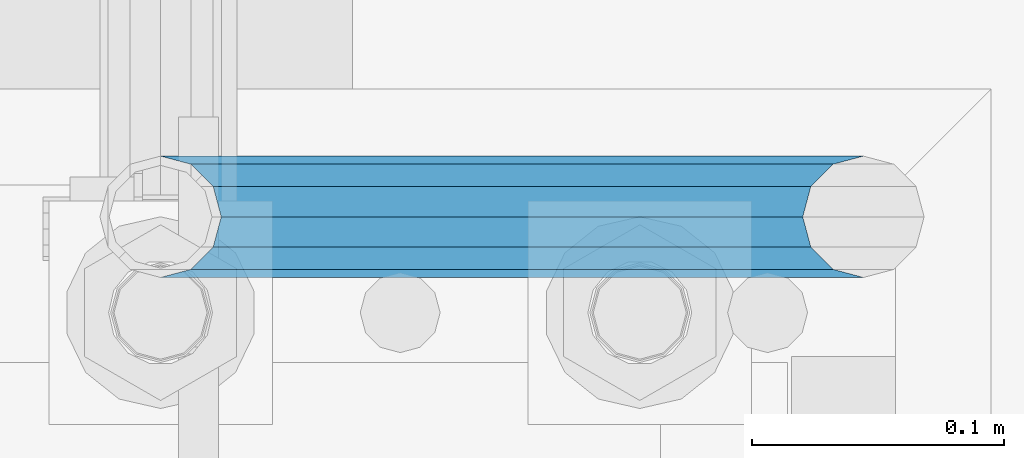
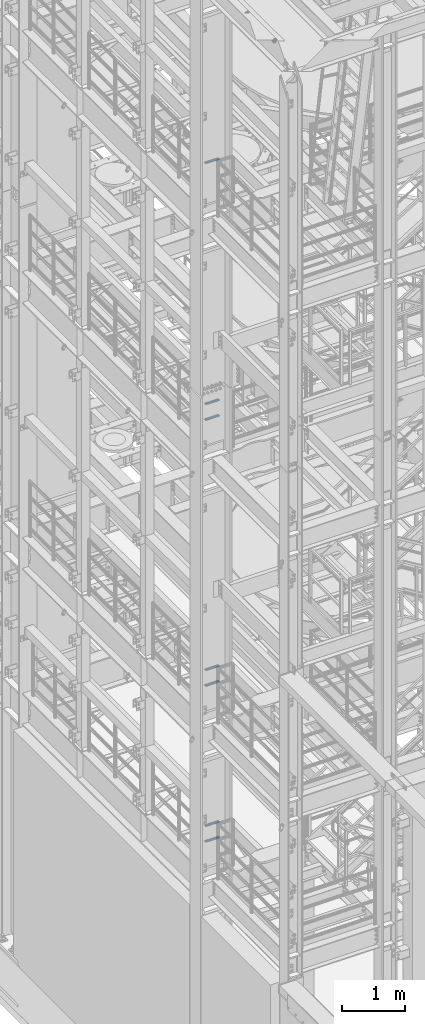
# One storey, part 1158 of 1876: 7 beams, 4 elements without a shape of their own.
"""IFC2X3 building model written with IfcOpenShell, lengths in millimetres."""

import ifcopenshell
import ifcopenshell.guid

model = None  # the IFC model being written
_history = None  # IfcOwnerHistory: only IFC2X3 demands one
_inside = {}  # id of a spatial element -> (the spatial element, [elements in it])
_under = {}  # id of a project, library or spatial element -> (it, [spatial elements below it])
_declared = {}  # id of a project -> (the project, [libraries it declares])
_typed = {}  # id of a type object -> (the type object, [elements of that type])
_made_of = {}  # id of a material, layer set ... -> (it, [elements and type objects made of it])


def new_model(schema):
    """Start an empty IFC model of exactly this schema.

    Asked for "IFC4X3", IfcOpenShell would pick the latest addendum, in which some entities
    have other attributes; the version numbers below select the first issue.
    IFC2X3 requires an IfcOwnerHistory on every rooted entity: one is made here for all.
    """
    global model, _history
    if schema == "IFC4X3":
        model = ifcopenshell.file(schema_version=(4, 3, 0, 0))
    else:
        model = ifcopenshell.file(schema=schema)
    _inside.clear()
    _under.clear()
    _declared.clear()
    _typed.clear()
    _made_of.clear()
    _history = None
    if model.schema == "IFC2X3":
        org = make("IfcOrganization", Name="unknown")
        user = make(
            "IfcPersonAndOrganization",
            ThePerson=make("IfcPerson", FamilyName="unknown"),
            TheOrganization=org,
        )
        app = make(
            "IfcApplication",
            ApplicationDeveloper=org,
            Version="unknown",
            ApplicationFullName="unknown",
            ApplicationIdentifier="unknown",
        )
        _history = make(
            "IfcOwnerHistory",
            OwningUser=user,
            OwningApplication=app,
            ChangeAction="ADDED",
            CreationDate=0,
        )
    return model


def make(cls, **values):
    """One entity of the class cls with the attributes given. An attribute that is None is left unset."""
    return model.create_entity(
        cls, **{name: value for name, value in values.items() if value is not None}
    )


def rooted(cls, **values):
    """An entity with a GlobalId (a new one), such as an element, a storey or a relation."""
    return make(cls, GlobalId=ifcopenshell.guid.new(), OwnerHistory=_history, **values)


def si_unit(unit_type, name, prefix=None):
    """IfcSIUnit, for example si_unit("LENGTHUNIT", "METRE", prefix="MILLI")."""
    return make("IfcSIUnit", UnitType=unit_type, Prefix=prefix, Name=name)


def assignment(units):
    """IfcUnitAssignment: the units of a project."""
    return None if units is None else make("IfcUnitAssignment", Units=units)


def point(xyz):
    """IfcCartesianPoint."""
    return None if xyz is None else make("IfcCartesianPoint", Coordinates=xyz)


def direction(xyz):
    """IfcDirection."""
    return None if xyz is None else make("IfcDirection", DirectionRatios=xyz)


def frame(location, z_axis=None, x_axis=None):
    """IfcAxis2Placement3D, a coordinate frame: its origin and axes. An axis left out is left unset."""
    return make(
        "IfcAxis2Placement3D",
        Location=point(location),
        Axis=direction(z_axis),
        RefDirection=direction(x_axis),
    )


def origin_with_axes():
    """The frame at (0, 0, 0) with the z axis (0, 0, 1) and the x axis (1, 0, 0) written out."""
    return frame((0.0, 0.0, 0.0), z_axis=(0.0, 0.0, 1.0), x_axis=(1.0, 0.0, 0.0))


def place(relative_to, where):
    """IfcLocalPlacement: puts the frame where relative to a parent placement (None: the world)."""
    return make(
        "IfcLocalPlacement", PlacementRelTo=relative_to, RelativePlacement=where
    )


def context(
    kind, dimensions, precision=None, world=None, true_north=None, identifier=None
):
    """IfcGeometricRepresentationContext, for example the 3D "Model" context."""
    return make(
        "IfcGeometricRepresentationContext",
        ContextIdentifier=identifier,
        ContextType=kind,
        CoordinateSpaceDimension=dimensions,
        Precision=precision,
        WorldCoordinateSystem=world,
        TrueNorth=true_north,
    )


def subcontext(parent, identifier, kind, view, scale=None):
    """IfcGeometricRepresentationSubContext, for example "Body" below "Model"."""
    return make(
        "IfcGeometricRepresentationSubContext",
        ContextIdentifier=identifier,
        ContextType=kind,
        ParentContext=parent,
        TargetScale=scale,
        TargetView=view,
    )


def project(units=None, contexts=None):
    """IfcProject with its units and contexts."""
    return rooted(
        "IfcProject",
        Name="project",
        RepresentationContexts=contexts,
        UnitsInContext=assignment(units),
    )


def spatial(cls, under=None, at=None, **own):
    """A site, building, storey or space (cls), placed at a placement, below another one or the project."""
    s = rooted(cls, ObjectPlacement=at, **own)
    if under is not None:
        _under.setdefault(under.id(), (under, []))[1].append(s)
    return s


def faces_of(points, faces, orient=None, outer=None):
    """IfcFace entities. A face is a list of loops; a loop is a list of indices into points, from 0.

    orient and outer hold one flag for each loop. By default every Orientation is true, the
    first loop of a face is its IfcFaceOuterBound and the others are IfcFaceBound.
    """
    made = []
    for i, loops in enumerate(faces):
        bounds = []
        for j, loop in enumerate(loops):
            is_outer = j == 0 if outer is None else outer[i][j]
            bounds.append(
                make(
                    "IfcFaceOuterBound" if is_outer else "IfcFaceBound",
                    Bound=make("IfcPolyLoop", Polygon=[points[k] for k in loop]),
                    Orientation=True if orient is None else orient[i][j],
                )
            )
        made.append(make("IfcFace", Bounds=bounds))
    return made


def faceted_brep(points, faces, orient=None, outer=None, voids=None):
    """IfcFacetedBrep: a solid bounded by flat faces; with voids (closed shells), ...WithVoids."""
    shared = [point(p) for p in points]
    hull = make("IfcClosedShell", CfsFaces=faces_of(shared, faces, orient, outer))
    if voids is None:
        return make("IfcFacetedBrep", Outer=hull)
    return make(
        "IfcFacetedBrepWithVoids",
        Outer=hull,
        Voids=[
            make(cls, CfsFaces=faces_of(shared, fs, o, b)) for cls, fs, o, b in voids
        ],
    )


def shape(context_of_items, identifier, shape_type, items):
    """IfcShapeRepresentation: the items that make up one representation, for example the "Body"."""
    return make(
        "IfcShapeRepresentation",
        ContextOfItems=context_of_items,
        RepresentationIdentifier=identifier,
        RepresentationType=shape_type,
        Items=items,
    )


def material(Name=None, Category=None):
    """IfcMaterial."""
    return make("IfcMaterial", Name=Name, Category=Category)


def made_of(thing, what):
    """Note that an element or type object is made of a material, layer set ...; save() writes the relation."""
    if what is not None:
        _made_of.setdefault(what.id(), (what, []))[1].append(thing)
    return thing


def type_object(cls, material=None, **own):
    """A type object (cls), such as IfcWallType, which elements share."""
    return made_of(rooted(cls, **own), material)


def element(
    cls,
    number,
    at=None,
    inside=None,
    cuts=None,
    type_object=None,
    material=None,
    context=None,
    identifier="Body",
    shape_type=None,
    held_by="IfcProductDefinitionShape",
    body=None,
    shapes=None,
    **own,
):
    """One element of the class cls, such as IfcWall. Its Tag is "e" and its number.

    at: its placement. inside: the storey or other place that contains it. cuts: it is an
    opening in that element (IfcRelVoidsElement). A single representation is given by context,
    identifier, shape_type and body (its items); several are given by shapes. held_by: the class
    of the entity that holds the representations. save() writes the other relations.
    """
    e = rooted(cls, Tag="e%d" % number, ObjectPlacement=at, **own)
    if body is not None:
        shapes = [shape(context, identifier, shape_type, body)]
    if shapes is not None:
        e.Representation = make(held_by, Representations=shapes)
    if inside is not None:
        _inside.setdefault(inside.id(), (inside, []))[1].append(e)
    if cuts is not None:
        rooted(
            "IfcRelVoidsElement", RelatingBuildingElement=cuts, RelatedOpeningElement=e
        )
    if type_object is not None:
        _typed.setdefault(type_object.id(), (type_object, []))[1].append(e)
    return made_of(e, material)


def aggregate(whole, parts):
    """IfcRelAggregates: a whole, such as a stair, and the parts it consists of."""
    return rooted("IfcRelAggregates", RelatingObject=whole, RelatedObjects=parts)


def save(model, path):
    """Write the relations noted so far, then the file.

    IfcRelAggregates (storeys below a building ...), IfcRelContainedInSpatialStructure (elements
    in a storey), IfcRelDefinesByType, IfcRelAssociatesMaterial and IfcRelDeclares: one each for
    every whole, place, type object, material and project.
    """
    for whole, parts in _under.values():
        aggregate(whole, parts)
    for where, things in _inside.values():
        rooted(
            "IfcRelContainedInSpatialStructure",
            RelatedElements=things,
            RelatingStructure=where,
        )
    for kind, things in _typed.values():
        rooted("IfcRelDefinesByType", RelatedObjects=things, RelatingType=kind)
    for what, things in _made_of.values():
        rooted("IfcRelAssociatesMaterial", RelatedObjects=things, RelatingMaterial=what)
    for by, libraries in _declared.values():
        rooted("IfcRelDeclares", RelatingContext=by, RelatedDefinitions=libraries)
    model.write(path)


model = new_model("IFC2X3")

# Units and contexts
model_context = context("Model", 3, precision=1e-05, world=origin_with_axes())
body_context = subcontext(model_context, "Body", "Model", "MODEL_VIEW")
ifc_project = project(units=[si_unit("LENGTHUNIT", "METRE", prefix="MILLI"), si_unit("AREAUNIT", "SQUARE_METRE"), si_unit("VOLUMEUNIT", "CUBIC_METRE"), si_unit("MASSUNIT", "GRAM", prefix="KILO"), si_unit("TIMEUNIT", "SECOND"), si_unit("PLANEANGLEUNIT", "RADIAN"), si_unit("SOLIDANGLEUNIT", "STERADIAN"), si_unit("THERMODYNAMICTEMPERATUREUNIT", "DEGREE_CELSIUS"), si_unit("LUMINOUSINTENSITYUNIT", "LUMEN")], contexts=[model_context])

# Site, building, storey
site_placement = place(None, origin_with_axes())
site = spatial("IfcSite", under=ifc_project, at=site_placement, CompositionType="ELEMENT")
building_placement = place(site_placement, origin_with_axes())
building = spatial("IfcBuilding", under=site, at=building_placement, Name="Undefined", CompositionType="ELEMENT")
storey_placement = place(building_placement, origin_with_axes())
storey = spatial("IfcBuildingStorey", under=building, at=storey_placement, Name="Undefined", CompositionType="ELEMENT", Elevation=0.0)

# Assembly, beam
assembly_1_placement = place(storey_placement, origin_with_axes())
assembly_1 = element("IfcElementAssembly", 1, at=assembly_1_placement, inside=storey, Name="RAIL", AssemblyPlace="NOTDEFINED", PredefinedType="RIGID_FRAME")
ifc_material = material()
beam_type = type_object("IfcBeamType", Name="PIPE1-1/2SCH40", PredefinedType="NOTDEFINED")
beam_1_placement = place(assembly_1_placement, frame((-1.00044417195022e-11, -4356.1, 18754.7250000359), z_axis=(0.0, 0.0, 1.0), x_axis=(1.0, 0.0, 0.0)))
beam_1 = element("IfcBeam", 2, at=beam_1_placement, type_object=beam_type, material=ifc_material, Name="RAIL", ObjectType="PIPE1-1/2SCH40", context=body_context, shape_type="Brep", body=[
    faceted_brep([(258.502800903171, -12.0650000000005, 20.8971929933177), (258.502800903171, -12.0650000000005, 15.8661214311796), (258.009372465309, -10.2235000000001, 17.7076214311819), (255.26999389649, 0.0, 20.4470000000001), (255.26999389649, 0.0, 24.130000000001), (258.009372465309, 10.2235000000001, 17.7076214311819), (258.502800903171, 12.0650000000005, 15.8661214311796), (258.502800903171, 12.0650000000005, 20.8971929933177), (279.399993896489, 24.1299999999992, 0.0), (267.33499389649, 20.8971929933177, 12.0649999999987), (267.33499389649, 20.8971929933177, -12.0649999999987), (264.145422334351, 17.7076214311801, 10.2235000000001), (266.884800903171, 20.4470000000001, 0.0), (264.145422334351, 17.7076214311801, -10.2235000000001), (258.502800903171, 12.0650000000005, -15.8661214311796), (258.502800903171, 12.0650000000005, -20.8971929933177), (258.009372465309, 10.2235000000001, -17.7076214311819), (255.26999389649, 0.0, -20.4470000000001), (255.26999389649, 0.0, -24.130000000001), (258.502800903171, -12.0650000000005, -15.8661214311796), (258.502800903171, -12.0650000000005, -20.8971929933177), (258.009372465309, -10.2235000000001, -17.7076214311819), (279.399993896489, -24.1299999999992, 0.0), (267.33499389649, -20.8971929933177, -12.0649999999987), (267.33499389649, -20.8971929933177, 12.0649999999987), (264.145422334351, -17.7076214311801, -10.2235000000001), (266.884800903171, -20.4470000000001, 0.0), (264.145422334351, -17.7076214311801, 10.2235000000001), (12.0650000000064, -20.8971929933177, -12.0649999999987), (20.8971929933249, -12.0650000000005, -20.8971929933177), (0.0, 24.1299999999992, 0.0), (12.0650000000064, 20.8971929933177, -12.0649999999987), (12.0650000000064, 20.8971929933177, 12.0649999999987), (20.8971929933249, 12.0650000000005, 20.8971929933177), (24.1300000000064, 0.0, 24.130000000001), (20.8971929933249, 12.0650000000005, -20.8971929933177), (24.1300000000063, 0.0, -24.130000000001), (24.1300000000063, 0.0, -20.4470000000001), (20.8971929933249, -12.0650000000005, -15.8661214311796), (21.3906214311868, -10.2235000000001, -17.7076214311819), (21.3906214311868, 10.2235000000001, -17.7076214311819), (20.8971929933249, 12.0650000000005, -15.8661214311796), (15.2545715621445, 17.7076214311801, -10.2235000000001), (12.5151929933249, 20.4470000000001, 0.0), (15.2545715621445, 17.7076214311801, 10.2235000000001), (20.8971929933249, 12.0650000000005, 15.8661214311796), (21.3906214311868, 10.2235000000001, 17.7076214311819), (24.1300000000064, 0.0, 20.4470000000001), (21.3906214311868, -10.2235000000001, 17.7076214311819), (20.8971929933249, -12.0650000000005, 15.8661214311796), (20.8971929933249, -12.0650000000005, 20.8971929933177), (12.0650000000064, -20.8971929933177, 12.0649999999987), (0.0, -24.1299999999992, 0.0), (15.2545715621445, -17.7076214311801, 10.2235000000001), (12.5151929933249, -20.4470000000001, 0.0), (15.2545715621445, -17.7076214311801, -10.2235000000001)], [[[0, 1, 2, 3, 4]], [[4, 3, 5, 6, 7]], [[8, 9, 10]], [[7, 6, 11, 12, 13, 14, 15, 10, 9]], [[16, 17, 18, 15, 14]], [[19, 20, 18, 17, 21]], [[22, 23, 24]], [[24, 23, 20, 19, 25, 26, 27, 1, 0]], [[28, 29, 20, 23]], [[30, 31, 32]], [[33, 34, 4, 7]], [[32, 33, 7, 9]], [[30, 32, 9, 8]], [[31, 30, 8, 10]], [[35, 31, 10, 15]], [[36, 35, 15, 18]], [[29, 36, 18, 20]], [[37, 36, 29, 38, 39]], [[40, 41, 35, 36, 37]], [[32, 31, 35, 41, 42, 43, 44, 45, 33]], [[33, 45, 46, 47, 34]], [[34, 47, 48, 49, 50]], [[34, 50, 0, 4]], [[50, 51, 24, 0]], [[51, 52, 22, 24]], [[52, 28, 23, 22]], [[51, 28, 52]], [[50, 49, 53, 54, 55, 38, 29, 28, 51]], [[55, 54, 26, 25]], [[21, 39, 38, 55, 25, 19]], [[37, 39, 21, 17]], [[40, 37, 17, 16]], [[42, 41, 40, 16, 14, 13]], [[43, 42, 13, 12]], [[44, 43, 12, 11]], [[5, 46, 45, 44, 11, 6]], [[47, 46, 5, 3]], [[48, 47, 3, 2]], [[53, 49, 48, 2, 1, 27]], [[54, 53, 27, 26]]]),
])
aggregate(assembly_1, [beam_1])

# Assembly, beams
assembly_2_placement = place(storey_placement, origin_with_axes())
assembly_2 = element("IfcElementAssembly", 3, at=assembly_2_placement, inside=storey, Name="RAIL", AssemblyPlace="NOTDEFINED", PredefinedType="RIGID_FRAME")
beam_2_placement = place(assembly_2_placement, frame((-1.00044417195022e-11, -4356.1, 13776.325000036), z_axis=(0.0, 0.0, 1.0), x_axis=(1.0, 0.0, 0.0)))
beam_2 = element("IfcBeam", 4, at=beam_2_placement, type_object=beam_type, material=ifc_material, Name="RAIL", ObjectType="PIPE1-1/2SCH40", context=body_context, shape_type="Brep", body=[
    faceted_brep([(258.502800903171, -12.0650000000005, 20.8971929933177), (258.502800903171, -12.0650000000005, 15.8661214311796), (258.009372465309, -10.2235000000001, 17.7076214311819), (255.26999389649, 0.0, 20.4470000000001), (255.26999389649, 0.0, 24.130000000001), (258.009372465309, 10.2235000000001, 17.7076214311819), (258.502800903171, 12.0650000000005, 15.8661214311796), (258.502800903171, 12.0650000000005, 20.8971929933177), (279.399993896489, 24.1299999999992, 0.0), (267.33499389649, 20.8971929933177, 12.0649999999987), (267.33499389649, 20.8971929933177, -12.0649999999987), (264.145422334351, 17.7076214311801, 10.2235000000001), (266.884800903171, 20.4470000000001, 0.0), (264.145422334351, 17.7076214311801, -10.2235000000001), (258.502800903171, 12.0650000000005, -15.8661214311796), (258.502800903171, 12.0650000000005, -20.8971929933177), (258.009372465309, 10.2235000000001, -17.7076214311819), (255.26999389649, 0.0, -20.4470000000001), (255.26999389649, 0.0, -24.130000000001), (258.502800903171, -12.0650000000005, -15.8661214311796), (258.502800903171, -12.0650000000005, -20.8971929933177), (258.009372465309, -10.2235000000001, -17.7076214311819), (279.399993896489, -24.1299999999992, 0.0), (267.33499389649, -20.8971929933177, -12.0649999999987), (267.33499389649, -20.8971929933177, 12.0649999999987), (264.145422334351, -17.7076214311801, -10.2235000000001), (266.884800903171, -20.4470000000001, 0.0), (264.145422334351, -17.7076214311801, 10.2235000000001), (12.0650000000064, -20.8971929933177, -12.0649999999987), (20.8971929933249, -12.0650000000005, -20.8971929933177), (0.0, 24.1299999999992, 0.0), (12.0650000000064, 20.8971929933177, -12.0649999999987), (12.0650000000064, 20.8971929933177, 12.0649999999987), (20.8971929933249, 12.0650000000005, 20.8971929933177), (24.1300000000064, 0.0, 24.130000000001), (20.8971929933249, 12.0650000000005, -20.8971929933177), (24.1300000000063, 0.0, -24.130000000001), (24.1300000000063, 0.0, -20.4470000000001), (20.8971929933249, -12.0650000000005, -15.8661214311796), (21.3906214311868, -10.2235000000001, -17.7076214311819), (21.3906214311868, 10.2235000000001, -17.7076214311819), (20.8971929933249, 12.0650000000005, -15.8661214311796), (15.2545715621445, 17.7076214311801, -10.2235000000001), (12.5151929933249, 20.4470000000001, 0.0), (15.2545715621445, 17.7076214311801, 10.2235000000001), (20.8971929933249, 12.0650000000005, 15.8661214311796), (21.3906214311868, 10.2235000000001, 17.7076214311819), (24.1300000000064, 0.0, 20.4470000000001), (21.3906214311868, -10.2235000000001, 17.7076214311819), (20.8971929933249, -12.0650000000005, 15.8661214311796), (20.8971929933249, -12.0650000000005, 20.8971929933177), (12.0650000000064, -20.8971929933177, 12.0649999999987), (0.0, -24.1299999999992, 0.0), (15.2545715621445, -17.7076214311801, 10.2235000000001), (12.5151929933249, -20.4470000000001, 0.0), (15.2545715621445, -17.7076214311801, -10.2235000000001)], [[[0, 1, 2, 3, 4]], [[4, 3, 5, 6, 7]], [[8, 9, 10]], [[7, 6, 11, 12, 13, 14, 15, 10, 9]], [[16, 17, 18, 15, 14]], [[19, 20, 18, 17, 21]], [[22, 23, 24]], [[24, 23, 20, 19, 25, 26, 27, 1, 0]], [[28, 29, 20, 23]], [[30, 31, 32]], [[33, 34, 4, 7]], [[32, 33, 7, 9]], [[30, 32, 9, 8]], [[31, 30, 8, 10]], [[35, 31, 10, 15]], [[36, 35, 15, 18]], [[29, 36, 18, 20]], [[37, 36, 29, 38, 39]], [[40, 41, 35, 36, 37]], [[32, 31, 35, 41, 42, 43, 44, 45, 33]], [[33, 45, 46, 47, 34]], [[34, 47, 48, 49, 50]], [[34, 50, 0, 4]], [[50, 51, 24, 0]], [[51, 52, 22, 24]], [[52, 28, 23, 22]], [[51, 28, 52]], [[50, 49, 53, 54, 55, 38, 29, 28, 51]], [[55, 54, 26, 25]], [[21, 39, 38, 55, 25, 19]], [[37, 39, 21, 17]], [[40, 37, 17, 16]], [[42, 41, 40, 16, 14, 13]], [[43, 42, 13, 12]], [[44, 43, 12, 11]], [[5, 46, 45, 44, 11, 6]], [[47, 46, 5, 3]], [[48, 47, 3, 2]], [[53, 49, 48, 2, 1, 27]], [[54, 53, 27, 26]]]),
])
beam_3_placement = place(assembly_2_placement, frame((-1.00044417195022e-11, -4356.1, 14081.1250000359), z_axis=(0.0, 0.0, 1.0), x_axis=(1.0, 0.0, 0.0)))
beam_3 = element("IfcBeam", 5, at=beam_3_placement, type_object=beam_type, material=ifc_material, Name="RAIL", ObjectType="PIPE1-1/2SCH40", context=body_context, shape_type="Brep", body=[
    faceted_brep([(258.502800903171, -12.0650000000005, 20.8971929933177), (258.502800903171, -12.0650000000005, 15.8661214311796), (258.009372465309, -10.2235000000001, 17.7076214311819), (255.26999389649, 0.0, 20.4470000000001), (255.26999389649, 0.0, 24.130000000001), (258.009372465309, 10.2235000000001, 17.7076214311819), (258.502800903171, 12.0650000000005, 15.8661214311796), (258.502800903171, 12.0650000000005, 20.8971929933177), (279.399993896489, 24.1299999999992, 0.0), (267.33499389649, 20.8971929933177, 12.0649999999987), (267.33499389649, 20.8971929933177, -12.0649999999987), (264.145422334351, 17.7076214311801, 10.2235000000001), (266.884800903171, 20.4470000000001, 0.0), (264.145422334351, 17.7076214311801, -10.2235000000001), (258.502800903171, 12.0650000000005, -15.8661214311796), (258.502800903171, 12.0650000000005, -20.8971929933177), (258.009372465309, 10.2235000000001, -17.7076214311819), (255.26999389649, 0.0, -20.4470000000001), (255.26999389649, 0.0, -24.130000000001), (258.502800903171, -12.0650000000005, -15.8661214311796), (258.502800903171, -12.0650000000005, -20.8971929933177), (258.009372465309, -10.2235000000001, -17.7076214311819), (279.399993896489, -24.1299999999992, 0.0), (267.33499389649, -20.8971929933177, -12.0649999999987), (267.33499389649, -20.8971929933177, 12.0649999999987), (264.145422334351, -17.7076214311801, -10.2235000000001), (266.884800903171, -20.4470000000001, 0.0), (264.145422334351, -17.7076214311801, 10.2235000000001), (12.0650000000064, -20.8971929933177, -12.0649999999987), (20.8971929933249, -12.0650000000005, -20.8971929933177), (0.0, 24.1299999999992, 0.0), (12.0650000000064, 20.8971929933177, -12.0649999999987), (12.0650000000064, 20.8971929933177, 12.0649999999987), (20.8971929933249, 12.0650000000005, 20.8971929933177), (24.1300000000064, 0.0, 24.130000000001), (20.8971929933249, 12.0650000000005, -20.8971929933177), (24.1300000000063, 0.0, -24.130000000001), (24.1300000000063, 0.0, -20.4470000000001), (20.8971929933249, -12.0650000000005, -15.8661214311796), (21.3906214311868, -10.2235000000001, -17.7076214311819), (21.3906214311868, 10.2235000000001, -17.7076214311819), (20.8971929933249, 12.0650000000005, -15.8661214311796), (15.2545715621445, 17.7076214311801, -10.2235000000001), (12.5151929933249, 20.4470000000001, 0.0), (15.2545715621445, 17.7076214311801, 10.2235000000001), (20.8971929933249, 12.0650000000005, 15.8661214311796), (21.3906214311868, 10.2235000000001, 17.7076214311819), (24.1300000000064, 0.0, 20.4470000000001), (21.3906214311868, -10.2235000000001, 17.7076214311819), (20.8971929933249, -12.0650000000005, 15.8661214311796), (20.8971929933249, -12.0650000000005, 20.8971929933177), (12.0650000000064, -20.8971929933177, 12.0649999999987), (0.0, -24.1299999999992, 0.0), (15.2545715621445, -17.7076214311801, 10.2235000000001), (12.5151929933249, -20.4470000000001, 0.0), (15.2545715621445, -17.7076214311801, -10.2235000000001)], [[[0, 1, 2, 3, 4]], [[4, 3, 5, 6, 7]], [[8, 9, 10]], [[7, 6, 11, 12, 13, 14, 15, 10, 9]], [[16, 17, 18, 15, 14]], [[19, 20, 18, 17, 21]], [[22, 23, 24]], [[24, 23, 20, 19, 25, 26, 27, 1, 0]], [[28, 29, 20, 23]], [[30, 31, 32]], [[33, 34, 4, 7]], [[32, 33, 7, 9]], [[30, 32, 9, 8]], [[31, 30, 8, 10]], [[35, 31, 10, 15]], [[36, 35, 15, 18]], [[29, 36, 18, 20]], [[37, 36, 29, 38, 39]], [[40, 41, 35, 36, 37]], [[32, 31, 35, 41, 42, 43, 44, 45, 33]], [[33, 45, 46, 47, 34]], [[34, 47, 48, 49, 50]], [[34, 50, 0, 4]], [[50, 51, 24, 0]], [[51, 52, 22, 24]], [[52, 28, 23, 22]], [[51, 28, 52]], [[50, 49, 53, 54, 55, 38, 29, 28, 51]], [[55, 54, 26, 25]], [[21, 39, 38, 55, 25, 19]], [[37, 39, 21, 17]], [[40, 37, 17, 16]], [[42, 41, 40, 16, 14, 13]], [[43, 42, 13, 12]], [[44, 43, 12, 11]], [[5, 46, 45, 44, 11, 6]], [[47, 46, 5, 3]], [[48, 47, 3, 2]], [[53, 49, 48, 2, 1, 27]], [[54, 53, 27, 26]]]),
])
aggregate(assembly_2, [beam_2, beam_3])

assembly_3_placement = place(storey_placement, origin_with_axes())
assembly_3 = element("IfcElementAssembly", 6, at=assembly_3_placement, inside=storey, Name="RAIL", AssemblyPlace="NOTDEFINED", PredefinedType="RIGID_FRAME")
beam_4_placement = place(assembly_3_placement, frame((-1.00044417195022e-11, -4356.1, 8620.125000036), z_axis=(0.0, 0.0, 1.0), x_axis=(1.0, 0.0, 0.0)))
beam_4 = element("IfcBeam", 7, at=beam_4_placement, type_object=beam_type, material=ifc_material, Name="RAIL", ObjectType="PIPE1-1/2SCH40", context=body_context, shape_type="Brep", body=[
    faceted_brep([(258.502800903171, -12.0650000000005, 20.8971929933177), (258.502800903171, -12.0650000000005, 15.8661214311796), (258.009372465309, -10.2235000000001, 17.7076214311819), (255.26999389649, 0.0, 20.4470000000001), (255.26999389649, 0.0, 24.130000000001), (258.009372465309, 10.2235000000001, 17.7076214311819), (258.502800903171, 12.0650000000005, 15.8661214311796), (258.502800903171, 12.0650000000005, 20.8971929933177), (279.399993896489, 24.1299999999992, 0.0), (267.33499389649, 20.8971929933177, 12.0649999999987), (267.33499389649, 20.8971929933177, -12.0649999999987), (264.145422334351, 17.7076214311801, 10.2235000000001), (266.884800903171, 20.4470000000001, 0.0), (264.145422334351, 17.7076214311801, -10.2235000000001), (258.502800903171, 12.0650000000005, -15.8661214311796), (258.502800903171, 12.0650000000005, -20.8971929933177), (258.009372465309, 10.2235000000001, -17.7076214311819), (255.26999389649, 0.0, -20.4470000000001), (255.26999389649, 0.0, -24.130000000001), (258.502800903171, -12.0650000000005, -15.8661214311796), (258.502800903171, -12.0650000000005, -20.8971929933177), (258.009372465309, -10.2235000000001, -17.7076214311819), (279.399993896489, -24.1299999999992, 0.0), (267.33499389649, -20.8971929933177, -12.0649999999987), (267.33499389649, -20.8971929933177, 12.0649999999987), (264.145422334351, -17.7076214311801, -10.2235000000001), (266.884800903171, -20.4470000000001, 0.0), (264.145422334351, -17.7076214311801, 10.2235000000001), (12.0650000000064, -20.8971929933177, -12.0649999999987), (20.8971929933249, -12.0650000000005, -20.8971929933177), (0.0, 24.1299999999992, 0.0), (12.0650000000064, 20.8971929933177, -12.0649999999987), (12.0650000000064, 20.8971929933177, 12.0649999999987), (20.8971929933249, 12.0650000000005, 20.8971929933177), (24.1300000000064, 0.0, 24.130000000001), (20.8971929933249, 12.0650000000005, -20.8971929933177), (24.1300000000063, 0.0, -24.130000000001), (24.1300000000063, 0.0, -20.4470000000001), (20.8971929933249, -12.0650000000005, -15.8661214311796), (21.3906214311868, -10.2235000000001, -17.7076214311819), (21.3906214311868, 10.2235000000001, -17.7076214311819), (20.8971929933249, 12.0650000000005, -15.8661214311796), (15.2545715621445, 17.7076214311801, -10.2235000000001), (12.5151929933249, 20.4470000000001, 0.0), (15.2545715621445, 17.7076214311801, 10.2235000000001), (20.8971929933249, 12.0650000000005, 15.8661214311796), (21.3906214311868, 10.2235000000001, 17.7076214311819), (24.1300000000064, 0.0, 20.4470000000001), (21.3906214311868, -10.2235000000001, 17.7076214311819), (20.8971929933249, -12.0650000000005, 15.8661214311796), (20.8971929933249, -12.0650000000005, 20.8971929933177), (12.0650000000064, -20.8971929933177, 12.0649999999987), (0.0, -24.1299999999992, 0.0), (15.2545715621445, -17.7076214311801, 10.2235000000001), (12.5151929933249, -20.4470000000001, 0.0), (15.2545715621445, -17.7076214311801, -10.2235000000001)], [[[0, 1, 2, 3, 4]], [[4, 3, 5, 6, 7]], [[8, 9, 10]], [[7, 6, 11, 12, 13, 14, 15, 10, 9]], [[16, 17, 18, 15, 14]], [[19, 20, 18, 17, 21]], [[22, 23, 24]], [[24, 23, 20, 19, 25, 26, 27, 1, 0]], [[28, 29, 20, 23]], [[30, 31, 32]], [[33, 34, 4, 7]], [[32, 33, 7, 9]], [[30, 32, 9, 8]], [[31, 30, 8, 10]], [[35, 31, 10, 15]], [[36, 35, 15, 18]], [[29, 36, 18, 20]], [[37, 36, 29, 38, 39]], [[40, 41, 35, 36, 37]], [[32, 31, 35, 41, 42, 43, 44, 45, 33]], [[33, 45, 46, 47, 34]], [[34, 47, 48, 49, 50]], [[34, 50, 0, 4]], [[50, 51, 24, 0]], [[51, 52, 22, 24]], [[52, 28, 23, 22]], [[51, 28, 52]], [[50, 49, 53, 54, 55, 38, 29, 28, 51]], [[55, 54, 26, 25]], [[21, 39, 38, 55, 25, 19]], [[37, 39, 21, 17]], [[40, 37, 17, 16]], [[42, 41, 40, 16, 14, 13]], [[43, 42, 13, 12]], [[44, 43, 12, 11]], [[5, 46, 45, 44, 11, 6]], [[47, 46, 5, 3]], [[48, 47, 3, 2]], [[53, 49, 48, 2, 1, 27]], [[54, 53, 27, 26]]]),
])
beam_5_placement = place(assembly_3_placement, frame((-1.00044417195022e-11, -4356.1, 8924.92500003594), z_axis=(0.0, 0.0, 1.0), x_axis=(1.0, 0.0, 0.0)))
beam_5 = element("IfcBeam", 8, at=beam_5_placement, type_object=beam_type, material=ifc_material, Name="RAIL", ObjectType="PIPE1-1/2SCH40", context=body_context, shape_type="Brep", body=[
    faceted_brep([(258.502800903171, -12.0650000000005, 20.8971929933177), (258.502800903171, -12.0650000000005, 15.8661214311796), (258.009372465309, -10.2235000000001, 17.7076214311819), (255.26999389649, 0.0, 20.4470000000001), (255.26999389649, 0.0, 24.130000000001), (258.009372465309, 10.2235000000001, 17.7076214311819), (258.502800903171, 12.0650000000005, 15.8661214311796), (258.502800903171, 12.0650000000005, 20.8971929933177), (279.399993896489, 24.1299999999992, 0.0), (267.33499389649, 20.8971929933177, 12.0649999999987), (267.33499389649, 20.8971929933177, -12.0649999999987), (264.145422334351, 17.7076214311801, 10.2235000000001), (266.884800903171, 20.4470000000001, 0.0), (264.145422334351, 17.7076214311801, -10.2235000000001), (258.502800903171, 12.0650000000005, -15.8661214311796), (258.502800903171, 12.0650000000005, -20.8971929933177), (258.009372465309, 10.2235000000001, -17.7076214311819), (255.26999389649, 0.0, -20.4470000000001), (255.26999389649, 0.0, -24.130000000001), (258.502800903171, -12.0650000000005, -15.8661214311796), (258.502800903171, -12.0650000000005, -20.8971929933177), (258.009372465309, -10.2235000000001, -17.7076214311819), (279.399993896489, -24.1299999999992, 0.0), (267.33499389649, -20.8971929933177, -12.0649999999987), (267.33499389649, -20.8971929933177, 12.0649999999987), (264.145422334351, -17.7076214311801, -10.2235000000001), (266.884800903171, -20.4470000000001, 0.0), (264.145422334351, -17.7076214311801, 10.2235000000001), (12.0650000000064, -20.8971929933177, -12.0649999999987), (20.8971929933249, -12.0650000000005, -20.8971929933177), (0.0, 24.1299999999992, 0.0), (12.0650000000064, 20.8971929933177, -12.0649999999987), (12.0650000000064, 20.8971929933177, 12.0649999999987), (20.8971929933249, 12.0650000000005, 20.8971929933177), (24.1300000000064, 0.0, 24.130000000001), (20.8971929933249, 12.0650000000005, -20.8971929933177), (24.1300000000063, 0.0, -24.130000000001), (24.1300000000063, 0.0, -20.4470000000001), (20.8971929933249, -12.0650000000005, -15.8661214311796), (21.3906214311868, -10.2235000000001, -17.7076214311819), (21.3906214311868, 10.2235000000001, -17.7076214311819), (20.8971929933249, 12.0650000000005, -15.8661214311796), (15.2545715621445, 17.7076214311801, -10.2235000000001), (12.5151929933249, 20.4470000000001, 0.0), (15.2545715621445, 17.7076214311801, 10.2235000000001), (20.8971929933249, 12.0650000000005, 15.8661214311796), (21.3906214311868, 10.2235000000001, 17.7076214311819), (24.1300000000064, 0.0, 20.4470000000001), (21.3906214311868, -10.2235000000001, 17.7076214311819), (20.8971929933249, -12.0650000000005, 15.8661214311796), (20.8971929933249, -12.0650000000005, 20.8971929933177), (12.0650000000064, -20.8971929933177, 12.0649999999987), (0.0, -24.1299999999992, 0.0), (15.2545715621445, -17.7076214311801, 10.2235000000001), (12.5151929933249, -20.4470000000001, 0.0), (15.2545715621445, -17.7076214311801, -10.2235000000001)], [[[0, 1, 2, 3, 4]], [[4, 3, 5, 6, 7]], [[8, 9, 10]], [[7, 6, 11, 12, 13, 14, 15, 10, 9]], [[16, 17, 18, 15, 14]], [[19, 20, 18, 17, 21]], [[22, 23, 24]], [[24, 23, 20, 19, 25, 26, 27, 1, 0]], [[28, 29, 20, 23]], [[30, 31, 32]], [[33, 34, 4, 7]], [[32, 33, 7, 9]], [[30, 32, 9, 8]], [[31, 30, 8, 10]], [[35, 31, 10, 15]], [[36, 35, 15, 18]], [[29, 36, 18, 20]], [[37, 36, 29, 38, 39]], [[40, 41, 35, 36, 37]], [[32, 31, 35, 41, 42, 43, 44, 45, 33]], [[33, 45, 46, 47, 34]], [[34, 47, 48, 49, 50]], [[34, 50, 0, 4]], [[50, 51, 24, 0]], [[51, 52, 22, 24]], [[52, 28, 23, 22]], [[51, 28, 52]], [[50, 49, 53, 54, 55, 38, 29, 28, 51]], [[55, 54, 26, 25]], [[21, 39, 38, 55, 25, 19]], [[37, 39, 21, 17]], [[40, 37, 17, 16]], [[42, 41, 40, 16, 14, 13]], [[43, 42, 13, 12]], [[44, 43, 12, 11]], [[5, 46, 45, 44, 11, 6]], [[47, 46, 5, 3]], [[48, 47, 3, 2]], [[53, 49, 48, 2, 1, 27]], [[54, 53, 27, 26]]]),
])
aggregate(assembly_3, [beam_4, beam_5])

assembly_4_placement = place(storey_placement, origin_with_axes())
assembly_4 = element("IfcElementAssembly", 9, at=assembly_4_placement, inside=storey, Name="RAIL", AssemblyPlace="NOTDEFINED", PredefinedType="RIGID_FRAME")
beam_6_placement = place(assembly_4_placement, frame((-1.00044417195022e-11, -4356.1, 5597.525000036), z_axis=(0.0, 0.0, 1.0), x_axis=(1.0, 0.0, 0.0)))
beam_6 = element("IfcBeam", 10, at=beam_6_placement, type_object=beam_type, material=ifc_material, Name="RAIL", ObjectType="PIPE1-1/2SCH40", context=body_context, shape_type="Brep", body=[
    faceted_brep([(258.502800903171, -12.0650000000005, 20.8971929933177), (258.502800903171, -12.0650000000005, 15.8661214311796), (258.009372465309, -10.2235000000001, 17.7076214311819), (255.26999389649, 0.0, 20.4470000000001), (255.26999389649, 0.0, 24.130000000001), (258.009372465309, 10.2235000000001, 17.7076214311819), (258.502800903171, 12.0650000000005, 15.8661214311796), (258.502800903171, 12.0650000000005, 20.8971929933177), (279.399993896489, 24.1299999999992, 0.0), (267.33499389649, 20.8971929933177, 12.0649999999987), (267.33499389649, 20.8971929933177, -12.0649999999987), (264.145422334351, 17.7076214311801, 10.2235000000001), (266.884800903171, 20.4470000000001, 0.0), (264.145422334351, 17.7076214311801, -10.2235000000001), (258.502800903171, 12.0650000000005, -15.8661214311796), (258.502800903171, 12.0650000000005, -20.8971929933177), (258.009372465309, 10.2235000000001, -17.7076214311819), (255.26999389649, 0.0, -20.4470000000001), (255.26999389649, 0.0, -24.130000000001), (258.502800903171, -12.0650000000005, -15.8661214311796), (258.502800903171, -12.0650000000005, -20.8971929933177), (258.009372465309, -10.2235000000001, -17.7076214311819), (279.399993896489, -24.1299999999992, 0.0), (267.33499389649, -20.8971929933177, -12.0649999999987), (267.33499389649, -20.8971929933177, 12.0649999999987), (264.145422334351, -17.7076214311801, -10.2235000000001), (266.884800903171, -20.4470000000001, 0.0), (264.145422334351, -17.7076214311801, 10.2235000000001), (12.0650000000064, -20.8971929933177, -12.0649999999987), (20.8971929933249, -12.0650000000005, -20.8971929933177), (0.0, 24.1299999999992, 0.0), (12.0650000000064, 20.8971929933177, -12.0649999999987), (12.0650000000064, 20.8971929933177, 12.0649999999987), (20.8971929933249, 12.0650000000005, 20.8971929933177), (24.1300000000064, 0.0, 24.130000000001), (20.8971929933249, 12.0650000000005, -20.8971929933177), (24.1300000000063, 0.0, -24.130000000001), (24.1300000000063, 0.0, -20.4470000000001), (20.8971929933249, -12.0650000000005, -15.8661214311796), (21.3906214311868, -10.2235000000001, -17.7076214311819), (21.3906214311868, 10.2235000000001, -17.7076214311819), (20.8971929933249, 12.0650000000005, -15.8661214311796), (15.2545715621445, 17.7076214311801, -10.2235000000001), (12.5151929933249, 20.4470000000001, 0.0), (15.2545715621445, 17.7076214311801, 10.2235000000001), (20.8971929933249, 12.0650000000005, 15.8661214311796), (21.3906214311868, 10.2235000000001, 17.7076214311819), (24.1300000000064, 0.0, 20.4470000000001), (21.3906214311868, -10.2235000000001, 17.7076214311819), (20.8971929933249, -12.0650000000005, 15.8661214311796), (20.8971929933249, -12.0650000000005, 20.8971929933177), (12.0650000000064, -20.8971929933177, 12.0649999999987), (0.0, -24.1299999999992, 0.0), (15.2545715621445, -17.7076214311801, 10.2235000000001), (12.5151929933249, -20.4470000000001, 0.0), (15.2545715621445, -17.7076214311801, -10.2235000000001)], [[[0, 1, 2, 3, 4]], [[4, 3, 5, 6, 7]], [[8, 9, 10]], [[7, 6, 11, 12, 13, 14, 15, 10, 9]], [[16, 17, 18, 15, 14]], [[19, 20, 18, 17, 21]], [[22, 23, 24]], [[24, 23, 20, 19, 25, 26, 27, 1, 0]], [[28, 29, 20, 23]], [[30, 31, 32]], [[33, 34, 4, 7]], [[32, 33, 7, 9]], [[30, 32, 9, 8]], [[31, 30, 8, 10]], [[35, 31, 10, 15]], [[36, 35, 15, 18]], [[29, 36, 18, 20]], [[37, 36, 29, 38, 39]], [[40, 41, 35, 36, 37]], [[32, 31, 35, 41, 42, 43, 44, 45, 33]], [[33, 45, 46, 47, 34]], [[34, 47, 48, 49, 50]], [[34, 50, 0, 4]], [[50, 51, 24, 0]], [[51, 52, 22, 24]], [[52, 28, 23, 22]], [[51, 28, 52]], [[50, 49, 53, 54, 55, 38, 29, 28, 51]], [[55, 54, 26, 25]], [[21, 39, 38, 55, 25, 19]], [[37, 39, 21, 17]], [[40, 37, 17, 16]], [[42, 41, 40, 16, 14, 13]], [[43, 42, 13, 12]], [[44, 43, 12, 11]], [[5, 46, 45, 44, 11, 6]], [[47, 46, 5, 3]], [[48, 47, 3, 2]], [[53, 49, 48, 2, 1, 27]], [[54, 53, 27, 26]]]),
])
beam_7_placement = place(assembly_4_placement, frame((-1.00044417195022e-11, -4356.1, 5902.32500003594), z_axis=(0.0, 0.0, 1.0), x_axis=(1.0, 0.0, 0.0)))
beam_7 = element("IfcBeam", 11, at=beam_7_placement, type_object=beam_type, material=ifc_material, Name="RAIL", ObjectType="PIPE1-1/2SCH40", context=body_context, shape_type="Brep", body=[
    faceted_brep([(258.502800903171, -12.0650000000005, 20.8971929933177), (258.502800903171, -12.0650000000005, 15.8661214311796), (258.009372465309, -10.2235000000001, 17.7076214311819), (255.26999389649, 0.0, 20.4470000000001), (255.26999389649, 0.0, 24.130000000001), (258.009372465309, 10.2235000000001, 17.7076214311819), (258.502800903171, 12.0650000000005, 15.8661214311796), (258.502800903171, 12.0650000000005, 20.8971929933177), (279.399993896489, 24.1299999999992, 0.0), (267.33499389649, 20.8971929933177, 12.0649999999987), (267.33499389649, 20.8971929933177, -12.0649999999987), (264.145422334351, 17.7076214311801, 10.2235000000001), (266.884800903171, 20.4470000000001, 0.0), (264.145422334351, 17.7076214311801, -10.2235000000001), (258.502800903171, 12.0650000000005, -15.8661214311796), (258.502800903171, 12.0650000000005, -20.8971929933177), (258.009372465309, 10.2235000000001, -17.7076214311819), (255.26999389649, 0.0, -20.4470000000001), (255.26999389649, 0.0, -24.130000000001), (258.502800903171, -12.0650000000005, -15.8661214311796), (258.502800903171, -12.0650000000005, -20.8971929933177), (258.009372465309, -10.2235000000001, -17.7076214311819), (279.399993896489, -24.1299999999992, 0.0), (267.33499389649, -20.8971929933177, -12.0649999999987), (267.33499389649, -20.8971929933177, 12.0649999999987), (264.145422334351, -17.7076214311801, -10.2235000000001), (266.884800903171, -20.4470000000001, 0.0), (264.145422334351, -17.7076214311801, 10.2235000000001), (12.0650000000064, -20.8971929933177, -12.0649999999987), (20.8971929933249, -12.0650000000005, -20.8971929933177), (0.0, 24.1299999999992, 0.0), (12.0650000000064, 20.8971929933177, -12.0649999999987), (12.0650000000064, 20.8971929933177, 12.0649999999987), (20.8971929933249, 12.0650000000005, 20.8971929933177), (24.1300000000064, 0.0, 24.130000000001), (20.8971929933249, 12.0650000000005, -20.8971929933177), (24.1300000000063, 0.0, -24.130000000001), (24.1300000000063, 0.0, -20.4470000000001), (20.8971929933249, -12.0650000000005, -15.8661214311796), (21.3906214311868, -10.2235000000001, -17.7076214311819), (21.3906214311868, 10.2235000000001, -17.7076214311819), (20.8971929933249, 12.0650000000005, -15.8661214311796), (15.2545715621445, 17.7076214311801, -10.2235000000001), (12.5151929933249, 20.4470000000001, 0.0), (15.2545715621445, 17.7076214311801, 10.2235000000001), (20.8971929933249, 12.0650000000005, 15.8661214311796), (21.3906214311868, 10.2235000000001, 17.7076214311819), (24.1300000000064, 0.0, 20.4470000000001), (21.3906214311868, -10.2235000000001, 17.7076214311819), (20.8971929933249, -12.0650000000005, 15.8661214311796), (20.8971929933249, -12.0650000000005, 20.8971929933177), (12.0650000000064, -20.8971929933177, 12.0649999999987), (0.0, -24.1299999999992, 0.0), (15.2545715621445, -17.7076214311801, 10.2235000000001), (12.5151929933249, -20.4470000000001, 0.0), (15.2545715621445, -17.7076214311801, -10.2235000000001)], [[[0, 1, 2, 3, 4]], [[4, 3, 5, 6, 7]], [[8, 9, 10]], [[7, 6, 11, 12, 13, 14, 15, 10, 9]], [[16, 17, 18, 15, 14]], [[19, 20, 18, 17, 21]], [[22, 23, 24]], [[24, 23, 20, 19, 25, 26, 27, 1, 0]], [[28, 29, 20, 23]], [[30, 31, 32]], [[33, 34, 4, 7]], [[32, 33, 7, 9]], [[30, 32, 9, 8]], [[31, 30, 8, 10]], [[35, 31, 10, 15]], [[36, 35, 15, 18]], [[29, 36, 18, 20]], [[37, 36, 29, 38, 39]], [[40, 41, 35, 36, 37]], [[32, 31, 35, 41, 42, 43, 44, 45, 33]], [[33, 45, 46, 47, 34]], [[34, 47, 48, 49, 50]], [[34, 50, 0, 4]], [[50, 51, 24, 0]], [[51, 52, 22, 24]], [[52, 28, 23, 22]], [[51, 28, 52]], [[50, 49, 53, 54, 55, 38, 29, 28, 51]], [[55, 54, 26, 25]], [[21, 39, 38, 55, 25, 19]], [[37, 39, 21, 17]], [[40, 37, 17, 16]], [[42, 41, 40, 16, 14, 13]], [[43, 42, 13, 12]], [[44, 43, 12, 11]], [[5, 46, 45, 44, 11, 6]], [[47, 46, 5, 3]], [[48, 47, 3, 2]], [[53, 49, 48, 2, 1, 27]], [[54, 53, 27, 26]]]),
])
aggregate(assembly_4, [beam_6, beam_7])

save(model, "model.ifc")
